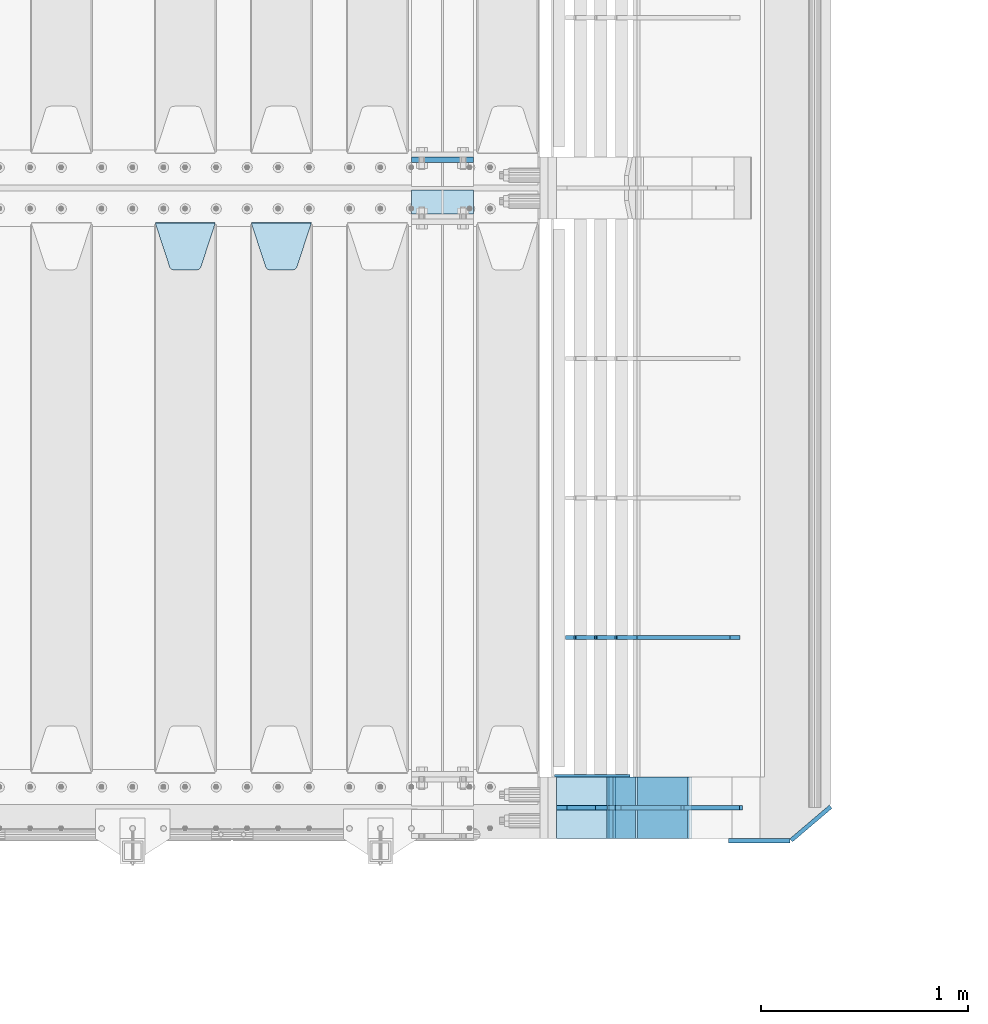
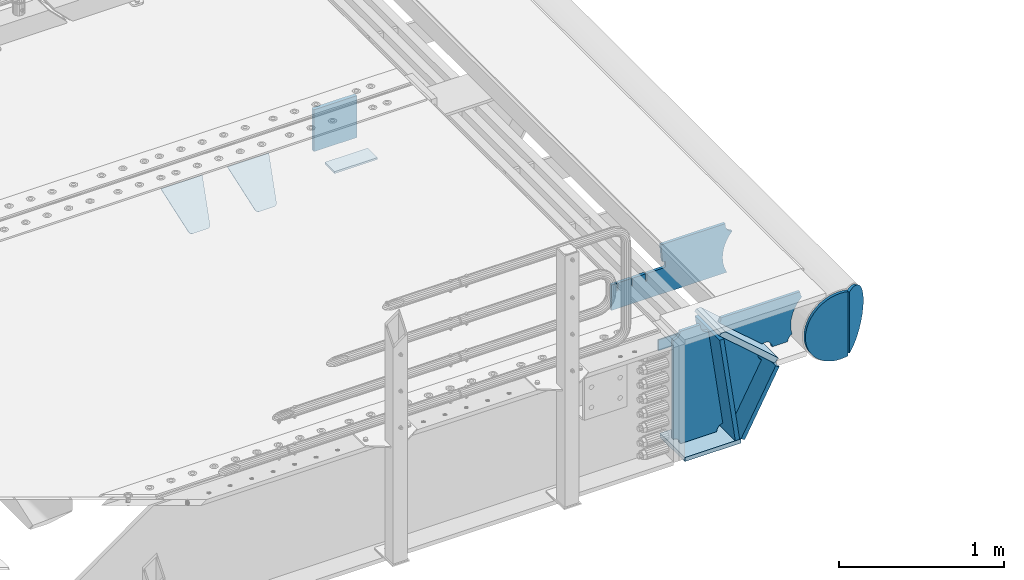
# One storey, part 189 of 208: 15 plates.
"""IFC2X3 building model written with IfcOpenShell, lengths in millimetres."""

from ifc_helpers import new_model, si_unit, frame, origin_with_axes, place, context, subcontext, project, spatial, faceted_brep, material, type_object, element, save


model = new_model("IFC2X3")

# Units and contexts
model_context = context("Model", 3, precision=1e-05, world=origin_with_axes())
body_context = subcontext(model_context, "Body", "Model", "MODEL_VIEW")
ifc_project = project(units=[si_unit("LENGTHUNIT", "METRE", prefix="MILLI"), si_unit("AREAUNIT", "SQUARE_METRE"), si_unit("VOLUMEUNIT", "CUBIC_METRE"), si_unit("MASSUNIT", "GRAM", prefix="KILO"), si_unit("TIMEUNIT", "SECOND"), si_unit("PLANEANGLEUNIT", "RADIAN"), si_unit("SOLIDANGLEUNIT", "STERADIAN"), si_unit("THERMODYNAMICTEMPERATUREUNIT", "DEGREE_CELSIUS"), si_unit("LUMINOUSINTENSITYUNIT", "LUMEN")], contexts=[model_context])

# Site, building, storey
site_placement = place(None, origin_with_axes())
site = spatial("IfcSite", under=ifc_project, at=site_placement, CompositionType="ELEMENT")
building_placement = place(site_placement, origin_with_axes())
building = spatial("IfcBuilding", under=site, at=building_placement, Name="Standard", CompositionType="ELEMENT")
storey_placement = place(building_placement, origin_with_axes())
storey = spatial("IfcBuildingStorey", under=building, at=storey_placement, Name="Undefined", CompositionType="ELEMENT", Elevation=0.0)

# Plates
ifc_material = material(Name="STEEL/S355N")
plate_type_1 = type_object("IfcPlateType", PredefinedType="NOTDEFINED")
plate_1_placement = place(storey_placement, frame((-26255.0, 3137.49999999999, -339.999999999993), z_axis=(0.0, 0.0, 1.0), x_axis=(1.0, 0.0, 0.0)))
element("IfcPlate", 1, at=plate_1_placement, inside=storey, type_object=plate_type_1, material=ifc_material, context=body_context, shape_type="Brep", body=[
    faceted_brep([(0.0, -12.5, 0.0), (0.0, -12.5, 310.0), (0.0, 12.5, 310.0), (0.0, 12.5, 0.0), (300.0, -12.5, 310.0), (300.0, 12.5, 310.0), (300.0, -12.5, 0.0), (300.0, 12.5, 0.0)], [[[0, 1, 2, 3]], [[1, 4, 5, 2]], [[4, 6, 7, 5]], [[6, 0, 3, 7]], [[5, 7, 3, 2]], [[6, 4, 1, 0]]]),
])
plate_type_2 = type_object("IfcPlateType", PredefinedType="NOTDEFINED")
plate_2_placement = place(storey_placement, frame((-26255.0, 2991.99999999999, -342.999999999993), z_axis=(0.0, -1.0, 0.0), x_axis=(1.0, 0.0, 0.0)))
element("IfcPlate", 2, at=plate_2_placement, inside=storey, type_object=plate_type_2, material=ifc_material, context=body_context, shape_type="Brep", body=[
    faceted_brep([(0.0, -7.0, 0.0), (0.0, -7.0, 117.0), (0.0, 7.0, 117.0), (0.0, 7.0, 0.0), (300.0, -7.0, 117.0), (300.0, 7.0, 117.0), (300.0, -7.0, 0.0), (300.0, 7.0, 0.0)], [[[0, 1, 2, 3]], [[1, 4, 5, 2]], [[4, 6, 7, 5]], [[6, 0, 3, 7]], [[5, 7, 3, 2]], [[6, 4, 1, 0]]]),
])
plate_type_3 = type_object("IfcPlateType", PredefinedType="NOTDEFINED")
plate_3_placement = place(storey_placement, frame((-27030.0, 2831.76776695596, -1.76776695296758), z_axis=(0.0, -0.707106781186548, -0.707106781186547), x_axis=(1.0, 0.0, 0.0)))
element("IfcPlate", 3, at=plate_3_placement, inside=storey, type_object=plate_type_3, material=ifc_material, context=body_context, shape_type="Brep", body=[
    faceted_brep([(0.0, -2.5, 0.0), (69.345504679477, -2.5, 300.17173142483), (69.345504679477, 2.5, 300.17173142483), (0.0, 2.5, 0.0), (70.9274061199576, -2.5, 304.897442415399), (70.9274061199576, 2.5, 304.8974424154), (73.3818627772307, -2.5, 309.234538108527), (73.3818627772307, 2.5, 309.234538108527), (76.6187032999551, -2.5, 313.023683126103), (76.6187032999551, 2.5, 313.023683126103), (80.5190132704993, -2.5, 316.125672595371), (80.5190132704993, 2.5, 316.125672595371), (84.9395038596849, -2.5, 318.426546230476), (84.9395038596849, 2.50000000000091, 318.426546230476), (89.7177759439219, -2.5, 319.841774983275), (89.7177759439219, 2.50000000000091, 319.841774983275), (94.678286292652, -2.49999999999909, 320.319366455078), (94.678286292652, 2.5, 320.319366455078), (195.321713707348, -2.49999999999909, 320.319366455078), (195.321713707348, 2.5, 320.319366455078), (200.282224056078, -2.5, 319.841774983275), (200.282224056078, 2.5, 319.841774983274), (205.060496140315, -2.5, 318.426546230475), (205.060496140315, 2.5, 318.426546230475), (209.480986729501, -2.5, 316.125672595371), (209.480986729501, 2.50000000000091, 316.125672595371), (213.381296700045, -2.5, 313.023683126102), (213.381296700045, 2.5, 313.023683126102), (216.618137222769, -2.5, 309.234538108526), (216.618137222769, 2.5, 309.234538108527), (219.072593880042, -2.5, 304.897442415399), (219.072593880042, 2.5, 304.897442415399), (220.654495320523, -2.5, 300.17173142483), (220.654495320523, 2.5, 300.17173142483), (290.0, -2.5, 0.0), (290.0, 2.5, 0.0)], [[[0, 1, 2, 3]], [[1, 4, 5, 2]], [[4, 6, 7, 5]], [[6, 8, 9, 7]], [[8, 10, 11, 9]], [[10, 12, 13, 11]], [[12, 14, 15, 13]], [[14, 16, 17, 15]], [[16, 18, 19, 17]], [[18, 20, 21, 19]], [[20, 22, 23, 21]], [[22, 24, 25, 23]], [[24, 26, 27, 25]], [[26, 28, 29, 27]], [[28, 30, 31, 29]], [[30, 32, 33, 31]], [[32, 34, 35, 33]], [[34, 0, 3, 35]], [[5, 7, 9, 11, 13, 15, 17, 19, 21, 23, 25, 27, 29, 31, 33, 35, 3, 2]], [[34, 32, 30, 28, 26, 24, 22, 20, 18, 16, 14, 12, 10, 8, 6, 4, 1, 0]]]),
])
plate_4_placement = place(storey_placement, frame((-27495.0, 2831.76776695596, -1.76776695296758), z_axis=(0.0, -0.707106781186548, -0.707106781186547), x_axis=(1.0, 0.0, 0.0)))
element("IfcPlate", 4, at=plate_4_placement, inside=storey, type_object=plate_type_3, material=ifc_material, context=body_context, shape_type="Brep", body=[
    faceted_brep([(0.0, -2.5, 0.0), (69.345504679477, -2.5, 300.17173142483), (69.345504679477, 2.5, 300.17173142483), (0.0, 2.5, 0.0), (70.9274061199576, -2.5, 304.897442415399), (70.9274061199576, 2.5, 304.8974424154), (73.3818627772307, -2.5, 309.234538108527), (73.3818627772307, 2.5, 309.234538108527), (76.6187032999551, -2.5, 313.023683126103), (76.6187032999551, 2.5, 313.023683126103), (80.5190132704993, -2.5, 316.125672595371), (80.5190132704993, 2.5, 316.125672595371), (84.9395038596849, -2.5, 318.426546230476), (84.9395038596849, 2.50000000000091, 318.426546230476), (89.7177759439219, -2.5, 319.841774983275), (89.7177759439219, 2.50000000000091, 319.841774983275), (94.678286292652, -2.49999999999909, 320.319366455078), (94.678286292652, 2.5, 320.319366455078), (195.321713707348, -2.49999999999909, 320.319366455078), (195.321713707348, 2.5, 320.319366455078), (200.282224056078, -2.5, 319.841774983275), (200.282224056078, 2.5, 319.841774983274), (205.060496140315, -2.5, 318.426546230475), (205.060496140315, 2.5, 318.426546230475), (209.480986729501, -2.5, 316.125672595371), (209.480986729501, 2.50000000000091, 316.125672595371), (213.381296700045, -2.5, 313.023683126102), (213.381296700045, 2.5, 313.023683126102), (216.618137222769, -2.5, 309.234538108526), (216.618137222769, 2.5, 309.234538108527), (219.072593880042, -2.5, 304.897442415399), (219.072593880042, 2.5, 304.897442415399), (220.654495320523, -2.5, 300.17173142483), (220.654495320523, 2.5, 300.17173142483), (290.0, -2.5, 0.0), (290.0, 2.5, 0.0)], [[[0, 1, 2, 3]], [[1, 4, 5, 2]], [[4, 6, 7, 5]], [[6, 8, 9, 7]], [[8, 10, 11, 9]], [[10, 12, 13, 11]], [[12, 14, 15, 13]], [[14, 16, 17, 15]], [[16, 18, 19, 17]], [[18, 20, 21, 19]], [[20, 22, 23, 21]], [[22, 24, 25, 23]], [[24, 26, 27, 25]], [[26, 28, 29, 27]], [[28, 30, 31, 29]], [[30, 32, 33, 31]], [[32, 34, 35, 33]], [[34, 0, 3, 35]], [[5, 7, 9, 11, 13, 15, 17, 19, 21, 23, 25, 27, 29, 31, 33, 35, 3, 2]], [[34, 32, 30, 28, 26, 24, 22, 20, 18, 16, 14, 12, 10, 8, 6, 4, 1, 0]]]),
])
plate_type_4 = type_object("IfcPlateType", PredefinedType="NOTDEFINED")
plate_5_placement = place(storey_placement, frame((-25160.0011701109, 150.0, -875.000000002935), z_axis=(0.0, -1.0, 0.0), x_axis=(-1.0, 0.0, 0.0)))
element("IfcPlate", 5, at=plate_5_placement, inside=storey, type_object=plate_type_4, material=ifc_material, context=body_context, shape_type="Brep", body=[
    faceted_brep([(0.0, -15.0, 0.0), (0.0, -15.0, 300.0), (0.0, 15.0, 300.0), (0.0, 15.0, 0.0), (393.0, -15.0, 300.0), (393.0, 15.0, 300.0), (393.0, -15.0, 1.50635059981141e-12), (393.0, 15.0, 1.50635059981141e-12)], [[[0, 1, 2, 3]], [[1, 4, 5, 2]], [[4, 6, 7, 5]], [[6, 0, 3, 7]], [[5, 7, 3, 2]], [[6, 4, 1, 0]]]),
])
plate_6_placement = place(storey_placement, frame((-25183.8519322773, 150.000000001004, -862.083788727077), z_axis=(-0.139173011053008, 0.0, 0.990268081377179), x_axis=(0.0, -1.0, 0.0)))
element("IfcPlate", 6, at=plate_6_placement, inside=storey, type_object=plate_type_4, material=ifc_material, context=body_context, shape_type="Brep", body=[
    faceted_brep([(1.00411057246674e-09, 14.9994702460535, -0.00376939767375006), (300.0, 15.0, 0.0), (300.0, -15.0, 4.21237841386846), (0.0, -15.0, 4.21237841386846), (0.0, -14.9999999999964, 792.0), (300.0, -14.9999999999964, 792.0), (300.0, 15.0, 792.0), (0.0, 15.0, 792.0)], [[[0, 1, 2, 3]], [[4, 5, 6, 7]], [[4, 7, 0, 3]], [[5, 4, 3, 2]], [[6, 5, 2, 1]], [[7, 6, 1, 0]]]),
])
plate_7_placement = place(storey_placement, frame((-25146.7531990427, 150.000000001004, -867.038754737719), z_axis=(0.469471552246176, 0.0, 0.882947598462992), x_axis=(0.0, -1.0, 0.0)))
element("IfcPlate", 7, at=plate_7_placement, inside=storey, type_object=plate_type_4, material=ifc_material, context=body_context, shape_type="Brep", body=[
    faceted_brep([(0.0, -15.0, 0.0), (0.0, -15.0000000000036, 514.999999999996), (0.0, 14.9999999999964, 514.999999999998), (0.0, 15.0, 0.0), (300.0, -15.0000000000036, 514.999999999996), (300.0, 14.9999999999964, 514.999999999998), (300.0, -15.0, 0.0), (300.0, 15.0, 0.0)], [[[0, 1, 2, 3]], [[1, 4, 5, 2]], [[4, 6, 7, 5]], [[6, 0, 3, 7]], [[5, 7, 3, 2]], [[6, 4, 1, 0]]]),
])
plate_type_5 = type_object("IfcPlateType", PredefinedType="NOTDEFINED")
plate_8_placement = place(storey_placement, frame((-24911.0011701102, 149.9999999992, -367.999999998984), z_axis=(-0.752989422949573, 0.0, 0.658032619955933), x_axis=(0.0, -1.0, 0.0)))
element("IfcPlate", 8, at=plate_8_placement, inside=storey, type_object=plate_type_5, material=ifc_material, context=body_context, shape_type="Brep", body=[
    faceted_brep([(-8.10757683211705e-10, 20.0, 490.766265601625), (4.54747350886464e-13, -0.30381125094209, 514.000000000004), (300.0, -0.30381125094209, 514.000000000004), (300.0, 20.0, 490.766265601625), (300.0, -20.0, 3.63797880709171e-12), (300.0, -20.0, 514.000000000004), (4.54747350886464e-13, -20.0, 514.000000000004), (0.0, -20.0, 0.0), (0.0, 20.0, 0.0), (300.0, 20.0, 3.63797880709171e-12)], [[[0, 1, 2, 3]], [[4, 5, 6, 7]], [[4, 7, 8, 9]], [[9, 8, 0, 3]], [[5, 4, 9, 3, 2]], [[6, 5, 2, 1]], [[8, 7, 6, 1, 0]]]),
])
plate_type_6 = type_object("IfcPlateType", PredefinedType="NOTDEFINED")
plate_9_placement = place(storey_placement, frame((-24596.0011701102, -6.40284270048141e-10, -29.9999999989843), z_axis=(-0.000446694000102124, 0.0, -0.99999990023223), x_axis=(-0.99999990023223, 0.0, 0.000446694000103734)))
element("IfcPlate", 9, at=plate_9_placement, inside=storey, type_object=plate_type_6, material=ifc_material, context=body_context, shape_type="Brep", body=[
    faceted_brep([(125.007775472979, 10.0, 291.842314882029), (131.755016800049, 10.0, 263.793234614468), (131.755016800049, -10.0, 263.793234614468), (125.007775472979, -10.0, 291.842314882029), (134.899927074479, 10.0, 224.060281342732), (134.899927074479, -10.0, 224.060281342732), (131.790514995217, 10.0, 184.324534302446), (131.790514995217, -10.0, 184.324534302446), (122.503344607205, 10.0, 145.564419461128), (122.503344607205, -10.0, 145.564419461128), (107.267096867741, 10.0, 108.734339483615), (107.267096867741, -10.0, 108.734339483615), (86.4569387623887, 10.0, 74.7411731709829), (86.4569387623887, -10.0, 74.7411731709829), (60.5852854486475, 10.0, 44.4219450946983), (60.5852854486475, -10.0, 44.4219450946983), (56.2519855253086, 10.0, 40.7176084148888), (56.2519855253086, -10.0, 40.7176084148888), (136.409234539125, -10.0, 297.721677540594), (147.386991180581, -10.0, 308.778803581017), (147.386991180581, 10.0, 308.778803581017), (136.409234539125, 10.0, 297.721677540594), (154.428166132755, -10.0, 322.678193223937), (154.428166132755, 10.0, 322.678193223937), (156.849001662973, -10.0, 338.070097995228), (156.849001662973, 10.0, 338.070097995228), (264.849004013293, -10.0, 338.118348049693), (264.849004013293, 10.0, 338.118348049693), (267.62876711955, -10.0, 321.701412969031), (267.62876711955, 10.0, 321.701412969031), (275.645118712175, -10.0, 307.107546191754), (275.645118712175, 10.0, 307.107546191754), (288.009068357209, -10.0, 295.955165748785), (288.009068357209, 10.0, 295.955165748785), (303.34948944753, -10.0, 289.481038692482), (303.34948944753, 10.0, 289.481038692482), (319.965173216922, -10.0, 288.403127172445), (319.965173216922, 10.0, 288.403127172445), (336.013487920231, -10.0, 292.840968489265), (336.013487920231, 10.0, 292.840968489265), (335.86907958984, -10.0, 293.150054931641), (335.86907958984, 10.0, 293.150054931641), (633.93705743644, -10.0, 32.8861672876965), (633.93705743644, 10.0, 32.8861672876965), (628.672097726398, -10.0, 25.6357574923157), (628.672097726398, 10.0, 25.6357574923157), (624.785781531267, -10.0, 17.5620477266101), (624.785781531267, 10.0, 17.5620477266101), (622.402919050601, -10.0, 8.92432757904926), (622.402919050601, 10.0, 8.92432757904926), (621.600036621094, -10.0, -8.74678107720683e-10), (621.600036621094, 10.0, -8.74678107720683e-10), (70.0, -10.0, -9.85025394584227e-11), (70.0, 10.0, -9.85025394584227e-11), (67.7728137216582, -10.0, 17.5170123094482), (67.7728137216582, 10.0, 17.5170123094482), (61.2329794213947, -10.0, 33.9193489203215), (61.2329794213947, 10.0, 33.9193489203215)], [[[0, 1, 2, 3]], [[4, 5, 2, 1]], [[6, 7, 5, 4]], [[8, 9, 7, 6]], [[10, 11, 9, 8]], [[12, 13, 11, 10]], [[14, 15, 13, 12]], [[16, 17, 15, 14]], [[18, 19, 20, 21]], [[19, 22, 23, 20]], [[22, 24, 25, 23]], [[24, 26, 27, 25]], [[26, 28, 29, 27]], [[28, 30, 31, 29]], [[30, 32, 33, 31]], [[32, 34, 35, 33]], [[34, 36, 37, 35]], [[36, 38, 39, 37]], [[38, 40, 41, 39]], [[40, 42, 43, 41]], [[42, 44, 45, 43]], [[44, 46, 47, 45]], [[46, 48, 49, 47]], [[48, 50, 51, 49]], [[50, 52, 53, 51]], [[52, 54, 55, 53]], [[54, 56, 57, 55]], [[12, 10, 8, 6, 4, 1, 0, 21, 20, 23, 25, 27, 29, 31, 33, 35, 37, 39, 41, 43, 45, 47, 49, 51, 53, 55, 57, 16, 14]], [[18, 21, 0, 3]], [[56, 54, 52, 50, 48, 46, 44, 42, 40, 38, 36, 34, 32, 30, 28, 26, 24, 22, 19, 18, 3, 2, 5, 7, 9, 11, 13, 15, 17]], [[57, 56, 17, 16]]]),
])
plate_type_7 = type_object("IfcPlateType", PredefinedType="NOTDEFINED")
plate_10_placement = place(storey_placement, frame((-24911.9974314966, 1.00408215075731e-09, -393.996688204089), z_axis=(-0.658066357015091, 0.0, -0.752959939017267), x_axis=(-0.752959939017268, 0.0, 0.65806635701509)))
element("IfcPlate", 10, at=plate_10_placement, inside=storey, type_object=plate_type_7, material=ifc_material, context=body_context, shape_type="Brep", body=[
    faceted_brep([(-11.3595226159632, -10.0, 48.6925173505915), (-112.015767301036, -10.0, 480.154833723627), (-112.015767301036, 10.0, 480.154833723627), (-11.3595226159632, 10.0, 48.6925173505915), (-104.567323293642, -10.0, 482.519601382544), (-104.567323293642, 10.0, 482.519601382544), (-97.5783311599989, -10.0, 486.016090073754), (-97.5783311599989, 10.0, 486.016090073754), (-91.2195220373833, -10.0, 490.558885551658), (-91.2195220373833, 10.0, 490.558885551658), (-85.646232588424, -10.0, 496.037013784004), (-85.646232588424, 10.0, 496.037013784004), (447.024482710491, -10.0, 32.8103372896367), (447.024482710491, 10.0, 32.8103372896367), (441.786973010392, -10.0, 25.5709623937255), (441.786973010392, 10.0, 25.5709623937255), (437.921644570128, -10.0, 17.5149526624118), (437.921644570128, 10.0, 17.5149526624118), (435.551940606492, -10.0, 8.89958500531793), (435.551940606492, 10.0, 8.89958500531793), (434.753540039059, -10.0, -5.16592990607023e-10), (434.753540039059, 10.0, -5.16592990607023e-10), (50.0, -10.0, 0.0), (50.0, 10.0, 0.0), (47.7668538974212, -10.0, 14.7759151575156), (47.7668538974212, 10.0, 14.7759151575156), (41.2668932502784, -10.0, 28.2319592212443), (41.2668932502784, 10.0, 28.2319592212443), (31.0807325300157, -10.0, 39.1661596968297), (31.0807325300157, 10.0, 39.1661596968297), (18.1182591411452, -10.0, 46.6018098971945), (18.1182591411452, 10.0, 46.6018098971945), (3.53735696080548, -10.0, 49.874714091733), (3.53735696080548, 10.0, 49.874714091733)], [[[0, 1, 2, 3]], [[1, 4, 5, 2]], [[4, 6, 7, 5]], [[6, 8, 9, 7]], [[8, 10, 11, 9]], [[10, 12, 13, 11]], [[12, 14, 15, 13]], [[14, 16, 17, 15]], [[16, 18, 19, 17]], [[18, 20, 21, 19]], [[20, 22, 23, 21]], [[22, 24, 25, 23]], [[24, 26, 27, 25]], [[26, 28, 29, 27]], [[28, 30, 31, 29]], [[30, 32, 33, 31]], [[32, 0, 3, 33]], [[5, 7, 9, 11, 13, 15, 17, 19, 21, 23, 25, 27, 29, 31, 33, 3, 2]], [[32, 30, 28, 26, 24, 22, 20, 18, 16, 14, 12, 10, 8, 6, 4, 1, 0]]]),
])
plate_type_8 = type_object("IfcPlateType", PredefinedType="NOTDEFINED")
plate_11_placement = place(storey_placement, frame((-25314.0011701109, 0.0, -30.0000000029351), z_axis=(0.0, 0.0, -1.0), x_axis=(-1.0, 0.0, 0.0)))
element("IfcPlate", 11, at=plate_11_placement, inside=storey, type_object=plate_type_8, material=ifc_material, context=body_context, shape_type="Brep", body=[
    faceted_brep([(-9.00602409638668, -10.0, 65.0), (-108.137843376921, -10.0, 780.473130459514), (-108.137843376921, 10.0, 780.473130459514), (-9.00602409638668, 10.0, 65.0), (-94.4157884488377, -10.0, 784.433672138112), (-94.4157884488377, 10.0, 784.433672138112), (-82.3732461236723, -10.0, 792.112074067144), (-82.3732461236723, 10.0, 792.112074067144), (-72.9927947992364, -10.0, 802.881837982249), (-72.9927947992364, 10.0, 802.881837982249), (-67.0398068183713, -10.0, 815.864234368775), (-67.0398068183713, 10.0, 815.864234368775), (-65.0, -10.0, 830.0), (-65.0, 10.0, 830.0), (189.0, -10.0, 830.0), (189.0, 10.0, 830.0), (191.447174185243, -10.0, 814.549150281253), (191.447174185243, 10.0, 814.549150281253), (198.549150281251, -10.0, 800.610737385376), (198.549150281251, 10.0, 800.610737385376), (209.610737385377, -10.0, 789.549150281253), (209.610737385377, 10.0, 789.549150281253), (223.549150281251, -10.0, 782.447174185242), (223.549150281251, 10.0, 782.447174185242), (239.0, -10.0, 780.0), (239.0, 10.0, 780.0), (239.0, -10.0, 50.0), (239.0, 10.0, 50.0), (223.549150281251, -10.0, 47.5528258147577), (223.549150281251, 10.0, 47.5528258147577), (209.610737385377, -10.0, 40.4508497187474), (209.610737385377, 10.0, 40.4508497187474), (198.549150281251, -10.0, 29.3892626146237), (198.549150281251, 10.0, 29.3892626146237), (191.447174185243, -10.0, 15.4508497187474), (191.447174185243, 10.0, 15.4508497187474), (189.0, -10.0, 0.0), (189.0, 10.0, 0.0), (50.4776502774184, -10.0, 0.0), (50.4776502774184, 10.0, 0.0), (47.3830020671812, -10.0, 22.3352870825933), (47.3830020671812, 10.0, 22.3352870825933), (42.8384615202776, -10.0, 37.3040735979326), (42.8384615202776, 10.0, 37.3040735979326), (33.8907372011709, -10.0, 50.1358952937587), (33.8907372011709, 10.0, 50.1358952937587), (21.4156947086703, -10.0, 59.5746840579253), (21.4156947086703, 10.0, 59.5746840579253), (6.63447812067898, -10.0, 64.6965054822873), (6.63447812067898, 10.0, 64.6965054822873)], [[[0, 1, 2, 3]], [[1, 4, 5, 2]], [[4, 6, 7, 5]], [[6, 8, 9, 7]], [[8, 10, 11, 9]], [[10, 12, 13, 11]], [[12, 14, 15, 13]], [[14, 16, 17, 15]], [[16, 18, 19, 17]], [[18, 20, 21, 19]], [[20, 22, 23, 21]], [[22, 24, 25, 23]], [[24, 26, 27, 25]], [[26, 28, 29, 27]], [[28, 30, 31, 29]], [[30, 32, 33, 31]], [[32, 34, 35, 33]], [[34, 36, 37, 35]], [[36, 38, 39, 37]], [[38, 40, 41, 39]], [[40, 42, 43, 41]], [[42, 44, 45, 43]], [[44, 46, 47, 45]], [[46, 48, 49, 47]], [[48, 0, 3, 49]], [[5, 7, 9, 11, 13, 15, 17, 19, 21, 23, 25, 27, 29, 31, 33, 35, 37, 39, 41, 43, 45, 47, 49, 3, 2]], [[48, 46, 44, 42, 40, 38, 36, 34, 32, 30, 28, 26, 24, 22, 20, 18, 16, 14, 12, 10, 8, 6, 4, 1, 0]]]),
])
plate_type_9 = type_object("IfcPlateType", PredefinedType="NOTDEFINED")
plate_12_placement = place(storey_placement, frame((-24667.0817660324, 824.999282836914, -374.002067436517), z_axis=(0.0, 0.0, 1.0), x_axis=(-1.0, 0.0, 0.0)))
element("IfcPlate", 12, at=plate_12_placement, inside=storey, type_object=plate_type_9, material=ifc_material, context=body_context, shape_type="Brep", body=[
    faceted_brep([(801.919404066546, -10.0, 188.0), (801.919404066546, 10.0, 188.0), (801.919404066546, 10.0000000000001, 132.002067436952), (801.919404066546, -10.0, 132.002067436952), (793.919404066546, 10.0000000000001, 132.002067436952), (793.919404066546, -10.0, 132.002067436952), (793.919404066546, 10.0000000000001, 180.002067436952), (793.919404066546, -10.0, 180.002067436952), (793.527856196906, 10.0000000000001, 182.474203391951), (793.527856196906, -10.0, 182.474203391951), (792.391540021545, 10.0000000000001, 184.704349455291), (792.391540021545, -10.0, 184.704349455291), (790.621686084887, 10.0000000000001, 186.474203391951), (790.621686084887, -10.0, 186.474203391951), (788.391540021545, 10.0000000000001, 187.610519567313), (788.391540021545, -10.0, 187.610519567313), (785.919404066546, -10.0, 188.002067436952), (785.919404066546, 10.0, 188.0), (841.0, -10.0, 188.0), (841.0, -10.0, 0.0), (841.0, 10.0, 0.0), (841.0, 10.0, 188.0), (33.3619566735979, -10.0, 0.0), (33.3619566735979, 10.0, 0.0), (36.2350612208174, -10.0, 4.68848050267007), (36.2350612208174, 10.0, 4.68848050267007), (51.4877592159428, -10.0, 41.5117508652783), (51.4877592159428, 10.0, 41.5117508652783), (60.792242588137, -10.0, 80.2677133162963), (60.792242588137, 10.0, 80.2677133162963), (63.9194040769726, -10.0, 120.002067436515), (63.9194040769726, 10.0, 120.002067436515), (60.792242588137, -10.0, 159.736421556734), (60.792242588137, 10.0, 159.736421556734), (51.4877592159428, -10.0, 198.492384007752), (51.4877592159428, 10.0, 198.492384007752), (36.2350612208174, -10.0, 235.31565437036), (36.2350612208174, 10.0, 235.31565437036), (15.4097206482074, -10.0, 269.299521518803), (15.4097206482074, 10.0, 269.299521518803), (-3.35474438098754, -10.0, 291.269887256574), (-3.35474438098754, 10.0, 291.269887256574), (-2.36881039375294, -10.0, 291.426043859339), (-2.36881039375294, 10.0, 291.426043859339), (17.1449676604716, -10.0, 301.368810393754), (17.1449676604716, 10.0, 301.368810393754), (32.6311896062471, -10.0, 316.855032339527), (32.6311896062471, 10.0, 316.855032339527), (42.573956140659, -10.0, 336.368810393754), (42.573956140659, 10.0, 336.368810393754), (46.0, -10.0, 358.0), (46.0, 10.0, 358.0), (45.0495205499174, -10.0, 364.001091067617), (45.0495205499174, 10.0, 364.001091067617), (495.040008544922, -10.0, 364.010009765625), (495.040008544922, 10.0, 364.010009765625), (483.600036621094, -10.0, 233.759994506836), (483.600036621094, 10.0, 233.759994506836), (472.0, -10.0, 233.759994506836), (472.0, 10.0, 233.759994506836), (468.909830056251, -10.0, 233.270559669787), (468.909830056251, 10.0, 233.270559669787), (466.122147477075, -10.0, 231.850164450585), (466.122147477075, 10.0, 231.850164450585), (463.909830056251, -10.0, 229.637847029761), (463.909830056251, 10.0, 229.637847029761), (462.489434837047, -10.0, 226.850164450585), (462.489434837047, 10.0, 226.850164450585), (462.0, -10.0, 223.759994506836), (462.0, 10.0, 223.759994506836), (462.0, -10.0, 198.0), (462.0, 10.0, 198.0), (462.489434837047, -10.0, 194.909830056251), (462.489434837047, 10.0, 194.909830056251), (463.909830056251, -10.0, 192.122147477075), (463.909830056251, 10.0, 192.122147477075), (466.122147477075, -10.0, 189.909830056251), (466.122147477075, 10.0, 189.909830056251), (468.909830056251, -10.0, 188.489434837048), (468.909830056251, 10.0, 188.489434837048), (472.0, -10.0, 188.0), (472.0, 10.0, 188.0), (585.919404066546, -10.0, 188.002067436952), (585.919404066546, 10.0, 188.0), (588.391540021545, -10.0, 187.610519567313), (588.391540021545, 10.0, 187.610519567313), (590.621686084887, -10.0, 186.474203391951), (590.621686084887, 10.0, 186.474203391951), (592.391540021545, -10.0, 184.704349455291), (592.391540021545, 10.0, 184.704349455291), (593.527856196906, -10.0, 182.474203391951), (593.527856196906, 10.0, 182.474203391951), (593.919404066546, -10.0, 180.002067436952), (593.919404066546, 10.0, 180.002067436952), (593.919404066546, -10.0, 132.002067436952), (593.919404066546, 10.0, 132.002067436952), (601.919404066546, -10.0, 132.002067436952), (601.919404066546, 10.0, 132.002067436952), (601.919404066546, -10.0, 188.0), (601.919404066546, 10.0, 188.0), (685.919404066546, -10.0, 188.002067436952), (685.919404066546, 10.0, 188.0), (688.391540021545, -10.0, 187.610519567313), (688.391540021545, 10.0, 187.610519567313), (690.621686084887, -10.0, 186.474203391951), (690.621686084887, 10.0, 186.474203391951), (692.391540021545, -10.0, 184.704349455291), (692.391540021545, 10.0, 184.704349455291), (693.527856196906, -10.0, 182.474203391951), (693.527856196906, 10.0, 182.474203391951), (693.919404066546, -10.0, 180.002067436952), (693.919404066546, 10.0, 180.002067436952), (693.919404066546, -10.0, 132.002067436952), (693.919404066546, 9.99999999999989, 132.002067436952), (701.919404066546, -10.0, 132.002067436952), (701.919404066546, 9.99999999999989, 132.002067436952), (701.919404066546, -10.0, 188.0), (701.919404066546, 10.0, 188.0)], [[[0, 1, 2, 3]], [[3, 2, 4, 5]], [[5, 4, 6, 7]], [[7, 6, 8, 9]], [[9, 8, 10, 11]], [[11, 10, 12, 13]], [[13, 12, 14, 15]], [[16, 15, 14, 17]], [[18, 19, 20, 21]], [[20, 19, 22, 23]], [[22, 24, 25, 23]], [[26, 27, 25, 24]], [[28, 29, 27, 26]], [[30, 31, 29, 28]], [[32, 33, 31, 30]], [[34, 35, 33, 32]], [[36, 37, 35, 34]], [[38, 39, 37, 36]], [[39, 38, 40, 41]], [[40, 42, 43, 41]], [[44, 45, 43, 42]], [[46, 47, 45, 44]], [[48, 49, 47, 46]], [[50, 51, 49, 48]], [[52, 53, 51, 50]], [[54, 55, 53, 52]], [[54, 56, 57, 55]], [[56, 58, 59, 57]], [[58, 60, 61, 59]], [[60, 62, 63, 61]], [[62, 64, 65, 63]], [[64, 66, 67, 65]], [[66, 68, 69, 67]], [[68, 70, 71, 69]], [[70, 72, 73, 71]], [[72, 74, 75, 73]], [[74, 76, 77, 75]], [[76, 78, 79, 77]], [[78, 80, 81, 79]], [[81, 80, 82, 83]], [[82, 84, 85, 83]], [[86, 87, 85, 84]], [[88, 89, 87, 86]], [[90, 91, 89, 88]], [[92, 93, 91, 90]], [[94, 95, 93, 92]], [[96, 97, 95, 94]], [[98, 99, 97, 96]], [[99, 98, 100, 101]], [[100, 102, 103, 101]], [[104, 105, 103, 102]], [[106, 107, 105, 104]], [[108, 109, 107, 106]], [[110, 111, 109, 108]], [[112, 113, 111, 110]], [[114, 115, 113, 112]], [[116, 117, 115, 114]], [[117, 116, 16, 17]], [[12, 10, 8, 6, 4, 2, 1, 21, 20, 23, 25, 27, 29, 31, 33, 35, 37, 39, 41, 43, 45, 47, 49, 51, 53, 55, 57, 59, 61, 63, 65, 67, 69, 71, 73, 75, 77, 79, 81, 83, 85, 87, 89, 91, 93, 95, 97, 99, 101, 103, 105, 107, 109, 111, 113, 115, 117, 17, 14]], [[18, 21, 1, 0]], [[116, 114, 112, 110, 108, 106, 104, 102, 100, 98, 96, 94, 92, 90, 88, 86, 84, 82, 80, 78, 76, 74, 72, 70, 68, 66, 64, 62, 60, 58, 56, 54, 52, 50, 48, 46, 44, 42, 40, 38, 36, 34, 32, 30, 28, 26, 24, 22, 19, 18, 0, 3, 5, 7, 9, 11, 13, 15, 16]]]),
])
plate_type_10 = type_object("IfcPlateType", PredefinedType="NOTDEFINED")
plate_13_placement = place(storey_placement, frame((-24232.9974739935, -159.999999999999, -498.0), z_axis=(0.0, 0.0, 1.0), x_axis=(-1.0, 0.0, 0.0)))
element("IfcPlate", 13, at=plate_13_placement, inside=storey, type_object=plate_type_10, material=ifc_material, context=body_context, shape_type="Brep", body=[
    faceted_brep([(244.0, -10.0, 0.0), (209.275179461318, -10.0, 2.48356818105242), (209.275179461318, 10.0, 2.48356818105242), (244.0, 10.0, 0.0), (278.724820538682, -10.0, 2.48356818105236), (278.724820538682, 10.0, 2.48356818105236), (312.742743869308, -10.0, 9.88371443806261), (312.742743869308, 10.0, 9.88371443806261), (345.361263172461, -10.0, 22.0497931334975), (345.361263172461, 10.0, 22.0497931334975), (375.916359459166, -10.0, 38.7341379891918), (375.916359459166, 10.0, 38.7341379891918), (403.78601908265, -10.0, 59.597103857561), (403.78601908265, 10.0, 59.597103857561), (428.402896142437, -10.0, 84.2139809173505), (428.402896142437, 10.0, 84.2139809173505), (449.265862010809, -10.0, 112.083640540834), (449.265862010809, 10.0, 112.083640540834), (465.950206866502, -10.0, 142.63873682754), (465.950206866502, 10.0, 142.63873682754), (478.116285561937, -10.0, 175.257256130691), (478.116285561937, 10.0, 175.257256130691), (485.516431818949, -10.0, 209.275179461318), (485.516431818949, 10.0, 209.275179461318), (488.0, -10.0, 244.0), (488.0, 10.0, 244.0), (485.516431818949, -10.0, 278.724820538682), (485.516431818949, 10.0, 278.724820538682), (478.116285561937, -10.0, 312.742743869309), (478.116285561937, 10.0, 312.742743869309), (465.950206866502, -10.0, 345.36126317246), (465.950206866502, 10.0, 345.36126317246), (449.265862010809, -10.0, 375.916359459166), (449.265862010809, 10.0, 375.916359459166), (428.402896142437, -10.0, 403.78601908265), (428.402896142437, 10.0, 403.78601908265), (403.78601908265, -10.0, 428.402896142439), (403.78601908265, 10.0, 428.402896142439), (375.916359459166, -10.0, 449.265862010808), (375.916359459166, 10.0, 449.265862010808), (345.361263172461, -10.0, 465.950206866503), (345.361263172461, 10.0, 465.950206866503), (312.742743869308, -10.0, 478.116285561937), (312.742743869308, 10.0, 478.116285561937), (278.724820538682, -10.0, 485.516431818948), (278.724820538682, 10.0, 485.516431818948), (244.0, -10.0, 488.0), (244.0, 10.0, 488.0), (209.275179461318, -10.0, 485.516431818948), (209.275179461318, 10.0, 485.516431818948), (189.372062160266, -10.0, 481.186773668839), (189.375193030173, -10.0, 6.81254525210147), (189.379743036825, 10.0, 6.81155545873969), (189.376612153854, 10.0, 481.187763459359)], [[[0, 1, 2, 3]], [[4, 0, 3, 5]], [[6, 4, 5, 7]], [[8, 6, 7, 9]], [[10, 8, 9, 11]], [[12, 10, 11, 13]], [[14, 12, 13, 15]], [[16, 14, 15, 17]], [[18, 16, 17, 19]], [[20, 18, 19, 21]], [[22, 20, 21, 23]], [[24, 22, 23, 25]], [[26, 24, 25, 27]], [[28, 26, 27, 29]], [[30, 28, 29, 31]], [[32, 30, 31, 33]], [[34, 32, 33, 35]], [[36, 34, 35, 37]], [[38, 36, 37, 39]], [[40, 38, 39, 41]], [[42, 40, 41, 43]], [[44, 42, 43, 45]], [[46, 44, 45, 47]], [[48, 46, 47, 49]], [[1, 0, 4, 6, 8, 10, 12, 14, 16, 18, 20, 22, 24, 26, 28, 30, 32, 34, 36, 38, 40, 42, 44, 46, 48, 50, 51]], [[2, 1, 51, 52]], [[49, 47, 45, 43, 41, 39, 37, 35, 33, 31, 29, 27, 25, 23, 21, 19, 17, 15, 13, 11, 9, 7, 5, 3, 2, 52, 53]], [[48, 49, 53, 50]], [[52, 51, 50, 53]]]),
])
plate_type_11 = type_object("IfcPlateType", PredefinedType="NOTDEFINED")
plate_14_placement = place(storey_placement, frame((-25198.001170099, 155.0, -249.999999999564), z_axis=(-1.0, 0.0, 0.0), x_axis=(0.0, 0.0, 1.0)))
element("IfcPlate", 14, at=plate_14_placement, inside=storey, type_object=plate_type_11, material=ifc_material, context=body_context, shape_type="Brep", body=[
    faceted_brep([(0.0, -5.0, 0.0), (0.0, -5.0, 365.0), (0.0, 5.0, 365.0), (0.0, 5.0, 0.0), (80.0, -5.0, 365.0), (80.0, 5.0, 365.0), (80.0, -5.0, 0.0), (80.0, 5.0, 0.0)], [[[0, 1, 2, 3]], [[1, 4, 5, 2]], [[4, 6, 7, 5]], [[6, 0, 3, 7]], [[5, 7, 3, 2]], [[6, 4, 1, 0]]]),
])
plate_type_12 = type_object("IfcPlateType", PredefinedType="NOTDEFINED")
plate_15_placement = place(storey_placement, frame((-24379.328144425, -125.94925200755, -30.6102092804267), z_axis=(-0.0672019629768904, -0.057352245980278, -0.996089662657469), x_axis=(-0.758955820878072, -0.64512069289633, 0.0883479119858026)))
element("IfcPlate", 15, at=plate_15_placement, inside=storey, type_object=plate_type_12, material=ifc_material, context=body_context, shape_type="Brep", body=[
    faceted_brep([(0.0, -10.0, 0.0), (-48.0487670880721, -10.0000000000036, 8.6701745986943), (-48.0487670880684, 9.99999999999818, 8.6701745986943), (0.0, 10.0, 0.0), (-93.1333465523603, -10.0000000000036, 25.6771621704104), (-93.1333465523603, 9.99999999999818, 25.6771621704104), (-133.522018422304, -10.0000000000036, 50.3669776916506), (-133.522018422307, 9.99999999999636, 50.3669776916506), (-167.658004744, -10.0000000000036, 81.7919921875), (-167.658004743997, 9.99999999999636, 81.7919921875002), (-194.131179785258, -10.0000000000036, 118.752670288086), (-194.131179785254, 9.99999999999818, 118.752670288086), (-212.241073575682, -10.0000000000018, 159.800354003907), (-212.241073575682, 9.99999999999818, 159.800354003906), (-220.965927082383, -10.0, 203.387512207032), (-220.965927082383, 9.99999999999818, 203.387512207031), (-220.078811594769, -10.0000000000036, 247.828140258789), (-220.078811594773, 9.99999999999454, 247.828140258789), (-209.490798890532, -10.0000000000036, 291.426422119141), (-209.490798890529, 9.99999999999636, 291.426422119141), (-189.979858330371, -10.0000000000036, 332.473327636719), (-189.979858330371, 9.99999999999636, 332.473327636719), (-161.934860153862, -10.0000000000036, 369.423980712891), (-161.934860153859, 9.99999999999818, 369.423980712891), (-126.533912576626, -10.0, 400.848876953125), (-126.533912576626, 9.99999999999818, 400.848876953125), (-85.1552428327996, -10.0000000000036, 425.539093017579), (-85.1552428328032, 9.99999999999818, 425.539093017578), (-39.3886450815153, -10.0000000000036, 442.546478271484), (-39.3886450815116, 9.99999999999818, 442.546478271485), (8.99617299734746, -10.0000000000018, 451.215240478516), (8.99617299734382, 9.99999999999818, 451.215240478516), (49.1690940856934, -10.0000000000018, -1.75077730091289e-11), (49.1690940856897, 9.99999999999636, -1.75077730091289e-11)], [[[0, 1, 2, 3]], [[1, 4, 5, 2]], [[4, 6, 7, 5]], [[6, 8, 9, 7]], [[8, 10, 11, 9]], [[10, 12, 13, 11]], [[12, 14, 15, 13]], [[14, 16, 17, 15]], [[16, 18, 19, 17]], [[18, 20, 21, 19]], [[20, 22, 23, 21]], [[22, 24, 25, 23]], [[24, 26, 27, 25]], [[26, 28, 29, 27]], [[28, 30, 31, 29]], [[30, 32, 33, 31]], [[32, 0, 3, 33]], [[5, 7, 9, 11, 13, 15, 17, 19, 21, 23, 25, 27, 29, 31, 33, 3, 2]], [[32, 30, 28, 26, 24, 22, 20, 18, 16, 14, 12, 10, 8, 6, 4, 1, 0]]]),
])

save(model, "model.ifc")
